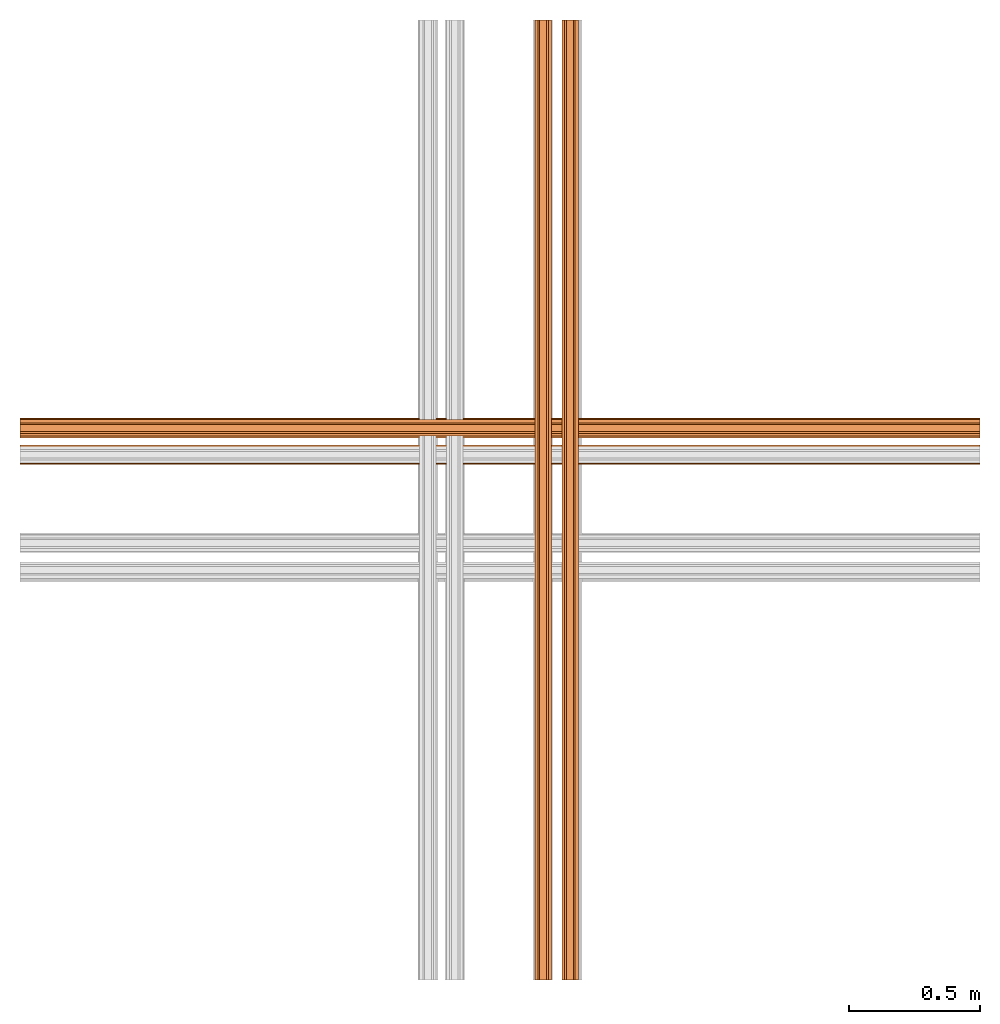
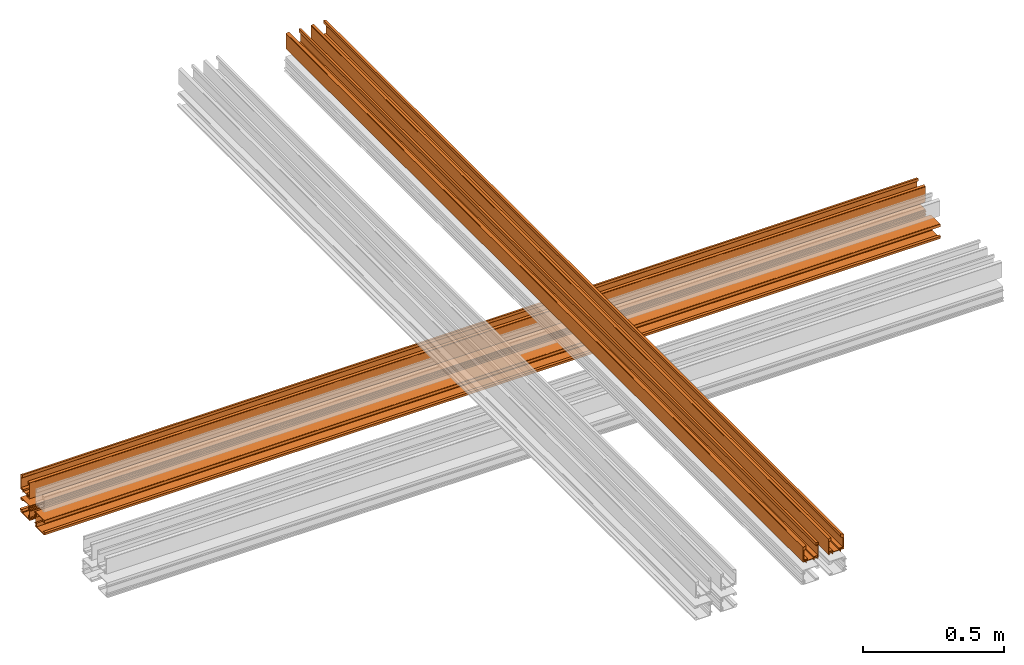
# One storey, part 2 of 4: 5 proxies.
"""IFC2X3 building model written with IfcOpenShell, lengths in feet."""

from ifc_helpers import new_model, entity, si_unit, converted_unit, derived_unit, direction, frame, origin, place, context, subcontext, project, spatial, polyline, outline, extrude, source, transform, mapped, material, type_object, type_shapes, element, save


model = new_model("IFC2X3")

# Units and contexts
model_context = context("Model", 3, precision=0.0001, world=origin(), true_north=direction((6.12303176911189e-17, 1.0)))
body_context = subcontext(model_context, "Body", "Model", "MODEL_VIEW")
ifc_project = project(units=[converted_unit("LENGTHUNIT", "FOOT", entity("IfcRatioMeasure", 0.3048), si_unit("LENGTHUNIT", "METRE"), dimensions=[1, 0, 0, 0, 0, 0, 0]), converted_unit("AREAUNIT", "SQUARE FOOT", entity("IfcRatioMeasure", 0.09290304), si_unit("AREAUNIT", "SQUARE_METRE"), dimensions=[2, 0, 0, 0, 0, 0, 0]), converted_unit("VOLUMEUNIT", "CUBIC FOOT", entity("IfcRatioMeasure", 0.028316846592), si_unit("VOLUMEUNIT", "CUBIC_METRE"), dimensions=[3, 0, 0, 0, 0, 0, 0]), converted_unit("PLANEANGLEUNIT", "DEGREE", entity("IfcRatioMeasure", 0.0174532925199433), si_unit("PLANEANGLEUNIT", "RADIAN"), dimensions=[0, 0, 0, 0, 0, 0, 0]), si_unit("MASSUNIT", "GRAM", prefix="KILO"), derived_unit("MASSDENSITYUNIT", [(si_unit("MASSUNIT", "GRAM", prefix="KILO"), 1), (si_unit("LENGTHUNIT", "METRE"), -3)]), si_unit("TIMEUNIT", "SECOND"), si_unit("FREQUENCYUNIT", "HERTZ"), si_unit("THERMODYNAMICTEMPERATUREUNIT", "DEGREE_CELSIUS"), derived_unit("THERMALTRANSMITTANCEUNIT", [(si_unit("MASSUNIT", "GRAM", prefix="KILO"), 1), (si_unit("THERMODYNAMICTEMPERATUREUNIT", "KELVIN"), -1), (si_unit("TIMEUNIT", "SECOND"), -3)]), derived_unit("VOLUMETRICFLOWRATEUNIT", [(si_unit("LENGTHUNIT", "METRE"), 3), (si_unit("TIMEUNIT", "SECOND"), -1)]), si_unit("ELECTRICCURRENTUNIT", "AMPERE"), si_unit("ELECTRICVOLTAGEUNIT", "VOLT"), si_unit("POWERUNIT", "WATT"), si_unit("FORCEUNIT", "NEWTON"), si_unit("ILLUMINANCEUNIT", "LUX"), si_unit("LUMINOUSFLUXUNIT", "LUMEN"), si_unit("LUMINOUSINTENSITYUNIT", "CANDELA"), derived_unit("USERDEFINED", [(si_unit("MASSUNIT", "GRAM", prefix="KILO"), -1), (si_unit("LENGTHUNIT", "METRE"), -2), (si_unit("TIMEUNIT", "SECOND"), 3), (si_unit("LUMINOUSFLUXUNIT", "LUMEN"), 1)]), derived_unit("LINEARVELOCITYUNIT", [(si_unit("LENGTHUNIT", "METRE"), 1), (si_unit("TIMEUNIT", "SECOND"), -1)]), si_unit("PRESSUREUNIT", "PASCAL"), derived_unit("USERDEFINED", [(si_unit("LENGTHUNIT", "METRE"), -2), (si_unit("MASSUNIT", "GRAM", prefix="KILO"), 1), (si_unit("TIMEUNIT", "SECOND"), -2)])], contexts=[model_context])

# Site, building, storey
site_placement = place(None, origin())
site = spatial("IfcSite", under=ifc_project, at=site_placement, CompositionType="ELEMENT")
building_placement = place(site_placement, origin())
building = spatial("IfcBuilding", under=site, at=building_placement, CompositionType="ELEMENT")
storey_placement = place(building_placement, origin())
storey = spatial("IfcBuildingStorey", under=building, at=storey_placement, Name="Level 1", CompositionType="ELEMENT", Elevation=0.0)

# Proxies
ifc_material = material(Name="THERMAL BROKEN ALUMINUM STOREFRONT FOR POLYCARBONATE")
building_element_proxy_type_1 = type_object("IfcBuildingElementProxyType", Name="Generic Models 2", PredefinedType="NOTDEFINED", material=ifc_material)
shared_shape_1 = source(origin(), body_context, "Body", "SweptSolid", [
    extrude(outline(polyline([(0.0679666623619384, 0.000632417738882034), (0.0710872151823903, 0.000632417738882035), (0.0725790120391962, 0.00314266314992642), (0.0702488184526767, 0.00635088523716412), (0.0700096732994308, 0.0109637083615167), (0.0775858665392128, 0.0113564851588285), (0.07705209294287, 0.0216523375102514), (-0.134304272308872, 0.0106948719853338), (-0.133377721915217, -0.00717717360587119), (-0.123081869563794, -0.00664340000952841), (-0.122412698736183, -0.000765203056200247), (-0.106181130798194, -0.00576720561552883), (-0.0921943125095251, -0.0050420792205001), (-0.0925870893068369, 0.002534114019282), (0.0533031958989615, 0.0100975851674486), (0.0553677918848111, -0.0297259946823094), (0.0598635549062831, -0.0294929183410442), (0.0628161856570255, 0.00318899968962119), (0.0662590259738256, 0.00336748877384732), (0.0679666623619384, 0.000632417738882034)])), frame((-15.047462540598, 0.320001633810749, 0.0977165289076384), z_axis=(1.0, 0.0, 0.0), x_axis=(0.0, -0.0517740246052117, -0.998658825813991)), (0.0, 0.0, 1.0), 12.0),
    extrude(outline(polyline([(-0.0104080468283571, -0.0212270141141864), (0.0284072982254619, -0.0212270141141864), (0.018596494374574, 0.0155635003266429), (-0.00515653981588799, 0.0270511459549446), (-0.00897742822638784, 0.0260322423788113), (-0.00514872339515063, 0.0116745992616715), (-0.00647401012520614, -0.00299045881680826), (-0.00136839731267838, -0.00250162354759878), (0.00181539143775607, -0.014440831361728), (-0.0112860383341234, -0.0179345459675626), (-0.0104080468283571, -0.0212270141141864)])), frame((-15.047462540598, 0.316819454437877, 0.217514651613355), z_axis=(1.0, 0.0, 0.0), x_axis=(0.0, -0.966234939601246, 0.257662650560335)), (0.0, 0.0, 1.0), 12.0),
    extrude(outline(polyline([(-0.0730229494703183, 0.10703462932325), (-0.0580447359626435, 0.10703462932325), (-0.0580447359626435, 0.113745897781071), (-0.0623242255363624, 0.118025006955696), (-0.0623242255363624, 0.112092207910207), (-0.067187281869896, 0.112092207910207), (-0.0704478474007049, 0.11773967307098), (-0.0704478474007049, 0.125224643652343), (-0.0675429204239739, 0.131454279657517), (-0.0623242255363623, 0.131454279657517), (-0.0623242255363623, 0.124783598829804), (-0.0580447359626435, 0.125514243391176), (-0.0580447359626435, 0.142048634925557), (-0.0813874063643328, 0.140085232742292), (-0.0813874063643332, -0.0647285203812247), (-0.0697160711634885, -0.0647285203812247), (-0.0697160711634885, -0.0853478792356713), (-0.0631023145498282, -0.0853478792356713), (-0.0631023145498281, -0.0647285203809973), (-0.0273102199340562, -0.0647285203809974), (-0.0273102199340562, -0.0853478792356714), (-0.0206964633203959, -0.0853478792356714), (-0.0206964633203958, -0.0647285203809974), (0.0812331974328893, -0.0647285203809976), (0.0812331974328893, -0.0853478792356715), (0.0878469540465496, -0.0853478792356716), (0.0878469540465497, -0.064728520381225), (0.116052680781773, -0.0647285203812251), (0.116052680781773, -0.060254508554083), (0.113329369234955, -0.058503808273967), (0.110217013181205, -0.0606435530609294), (0.0878469540467771, -0.0606435530609294), (0.0835674644730583, -0.0563640634872106), (0.0713125625121714, -0.0563640634872106), (0.0713125625121714, -0.038857060686171), (0.11546911402173, -0.0388570606861711), (0.11546911402173, -0.0337994820992142), (0.064698805898511, -0.0337994820992141), (0.064698805898511, -0.0563640634872106), (-0.0203074188135494, -0.0563640634872104), (-0.0203074188135494, -0.0337994820992139), (-0.0730229494703186, -0.0337994820992139), (-0.0730229494703183, 0.10703462932325)]), holes=[polyline([(-0.0710777269369962, -0.057725719260718), (-0.0710777269369961, -0.0388570606861708), (-0.0273102199340561, -0.0388570606861708), (-0.0273102199340562, -0.057725719260718), (-0.0710777269369962, -0.057725719260718)])]), frame((-15.047462540598, 0.210689707839806, 0.0853478792356716), z_axis=(1.0, 0.0, 0.0), x_axis=(0.0, 1.0, 0.0)), (0.0, 0.0, 1.0), 12.0),
    extrude(outline(polyline([(-0.0218274236802372, -0.0250762096884888), (0.0116463755794956, -0.0250762096884888), (0.0131456738465899, -0.018346801187307), (-0.00944342914962784, -0.0152716423802919), (-0.00556193395869953, 0.00214995231397128), (0.000832544625431264, 0.00182921635388849), (-0.000621696809064671, -0.00469796031725742), (0.00265859892029523, -0.00542880340721438), (0.00663400184610042, -0.000259219921661488), (0.00811823413249322, 0.00640256685218494), (0.00642611525779217, 0.0117890219260675), (0.00293818751194471, 0.0125661249989722), (0.00132974729935327, 0.00534684683544014), (-0.00324578604653776, 0.01254568596629), (-0.00165600184121945, 0.0196812290274095), (-0.0113732075341089, 0.0218462023164868), (-0.0218274236802372, -0.0250762096884888)])), frame((-15.047462540598, 0.147755316042005, 0.211232600832546), z_axis=(1.0, 0.0, 0.0), x_axis=(0.0, -0.976067916921979, -0.217465908950321)), (0.0, 0.0, 1.0), 12.0),
])
type_shapes(building_element_proxy_type_1, [shared_shape_1])
proxy_1_placement = place(storey_placement, frame((15.047462540598, 1.44024913148407, 0.30116151530084)))
element("IfcBuildingElementProxy", 1, at=proxy_1_placement, inside=storey, type_object=building_element_proxy_type_1, material=ifc_material, Name="Generic Models 4:Generic Models 2", ObjectType="Generic Models 4:Generic Models 2", context=body_context, shape_type="MappedRepresentation", body=[
    mapped(shared_shape_1, transform((0.0, 0.0, 0.0), scale=1.0)),
])
building_element_proxy_type_2 = type_object("IfcBuildingElementProxyType", Name="Generic Models 2", PredefinedType="NOTDEFINED", material=ifc_material)
shared_shape_2 = source(origin(), body_context, "Body", "SweptSolid", [
    extrude(outline(polyline([(-0.0178285177675846, -0.0155260272187081), (-0.0144209943882473, -0.0155260272187081), (-0.0144209943882478, -0.00196676824874534), (-0.00206457119881464, -0.00196676824874493), (-0.00122137518562342, -0.00702594432743685), (0.0126070394294666, -0.0019667682487444), (0.0274664100946021, -0.00196676824874392), (0.027466410094602, 0.00198764102989041), (0.0102463757664141, 0.0219787153649712), (-0.0278297824565667, 0.0219787153649699), (-0.0178285177675846, -0.0155260272187081)])), frame((-15.047462540598, -0.420840541578669, -0.488678668263246), z_axis=(1.0, 0.0, 0.0), x_axis=(0.0, 1.0, 0.0)), (0.0, 0.0, 1.0), 12.0),
    extrude(outline(polyline([(-0.0354587820648082, -0.0579874289764482), (-0.0371114306935165, -0.0606344277326359), (-0.0357721806658744, -0.0632292686235396), (-0.0318167433379171, -0.0629517678914729), (-0.0277772795930209, -0.0651918706200441), (-0.0314564692543414, -0.0718263669125336), (-0.0224403589082041, -0.076826291324035), (0.0801995988221872, 0.10825914370601), (0.0645489921835603, 0.116938257778832), (0.0595490677720589, 0.107922147432694), (0.064180835476401, 0.104241425091678), (0.0513416446814535, 0.0931221172418154), (0.0445492945375544, 0.0808738163942819), (0.0511837908300439, 0.0771946267329613), (-0.0196641946988635, -0.0505619557187232), (-0.0545378290564898, -0.0312226254478629), (-0.0567210844599414, -0.0351595792918129), (-0.0305624709345725, -0.0549725228627149), (-0.03223440063571, -0.0579874289764482), (-0.0354587820648082, -0.0579874289764482)])), frame((-15.047462540598, -0.301042418872953, -0.491860847636118), z_axis=(-1.0, 0.0, 0.0), x_axis=(0.0, -0.484973800275861, -0.874528680516533)), (0.0, 0.0, -1.0), 12.0),
    extrude(outline(polyline([(-0.10703462932325, -0.073022949470319), (-0.10703462932325, -0.0580447359626442), (-0.113745897781071, -0.0580447359626442), (-0.118025006955696, -0.062324225536363), (-0.112092207910207, -0.0623242255363631), (-0.112092207910207, -0.0671872818698967), (-0.11773967307098, -0.0704478474007056), (-0.125224643652343, -0.0704478474007056), (-0.131454279657517, -0.0675429204239747), (-0.131454279657517, -0.062324225536363), (-0.124783598829804, -0.062324225536363), (-0.125514243391176, -0.0580447359626443), (-0.142048634925557, -0.0580447359626443), (-0.140085232742292, -0.0813874063643334), (0.0647285203812248, -0.0813874063643335), (0.0647285203812249, -0.0697160711634889), (0.0853478792356714, -0.0697160711634888), (0.0853478792356714, -0.0631023145498285), (0.0647285203809975, -0.0631023145498285), (0.0647285203809975, -0.0273102199340566), (0.0853478792356714, -0.0273102199340566), (0.0853478792356714, -0.0206964633203962), (0.0647285203809975, -0.0206964633203962), (0.0647285203809975, 0.0812331974328889), (0.0853478792356714, 0.0812331974328889), (0.0853478792356714, 0.0878469540465494), (0.0647285203812249, 0.0878469540465494), (0.0647285203812249, 0.116052680781772), (0.0602545085540828, 0.116052680781772), (0.0585038082739668, 0.113329369234955), (0.0606435530609293, 0.110217013181204), (0.0606435530609293, 0.0878469540467767), (0.0563640634872104, 0.0835674644730579), (0.0563640634872104, 0.071312562512171), (0.0388570606861709, 0.071312562512171), (0.0388570606861709, 0.11546911402173), (0.033799482099214, 0.11546911402173), (0.033799482099214, 0.0646988058985107), (0.0563640634872105, 0.0646988058985107), (0.0563640634872105, -0.0203074188135498), (0.033799482099214, -0.0203074188135498), (0.033799482099214, -0.073022949470319), (-0.10703462932325, -0.073022949470319)]), holes=[polyline([(0.0577257192607181, -0.0710777269369965), (0.0388570606861709, -0.0710777269369965), (0.0388570606861709, -0.0273102199340565), (0.0577257192607181, -0.0273102199340565), (0.0577257192607181, -0.0710777269369965)])]), frame((-15.047462540598, -0.288673769200986, -0.382548921665175), z_axis=(-1.0, 0.0, 0.0), x_axis=(0.0, 1.0, 0.0)), (0.0, 0.0, -1.0), 12.0),
    extrude(outline(polyline([(-0.0292228042856086, -0.0158518272304065), (0.0188500922736236, -0.0158518272304065), (0.0188500922736236, -0.00589636662728316), (0.0115395937546052, -0.00589636662728316), (0.00550806035789692, 0.000135166769425155), (0.0129043470694794, 0.000135166769425099), (0.0129043470694794, 0.00370861456478611), (0.00801477925505995, 0.00653160785866191), (0.00118965299247947, 0.00653160785866191), (-0.00472072620232239, 0.003775552777526), (-0.00472072620232239, 0.000414827901224046), (0.00196648946985056, 0.000414827901224102), (0.000888968452729122, -0.0058963666272831), (-0.0169597840697409, -0.00589636662728321), (-0.0150489881052634, 0.0168208742845053), (-0.0219433941035703, 0.0168208742845053), (-0.0292228042856086, -0.0158518272304065)])), frame((-15.047462540598, -0.41455849079786, -0.319614529867374), z_axis=(1.0, 0.0, 0.0), x_axis=(0.0, 1.0, 0.0)), (0.0, 0.0, 1.0), 12.0),
])
type_shapes(building_element_proxy_type_2, [shared_shape_2])
proxy_2_placement = place(storey_placement, frame((15.047462540598, 1.66419438030405, 0.509494848634327)))
element("IfcBuildingElementProxy", 2, at=proxy_2_placement, inside=storey, type_object=building_element_proxy_type_2, material=ifc_material, Name="Generic Models 7:Generic Models 2", ObjectType="Generic Models 7:Generic Models 2", context=body_context, shape_type="MappedRepresentation", body=[
    mapped(shared_shape_2, transform((0.0, 0.0, 0.0), scale=1.0)),
])
building_element_proxy_type_3 = type_object("IfcBuildingElementProxyType", Name="Generic Models 2", PredefinedType="NOTDEFINED", material=ifc_material)
shared_shape_3 = source(origin(), body_context, "Body", "SweptSolid", [
    extrude(outline(polyline([(-0.0104080468283571, -0.0212270141141865), (0.0284072982254619, -0.0212270141141865), (0.0185964943745741, 0.0155635003266429), (-0.00515653981588791, 0.0270511459549447), (-0.00897742822638776, 0.0260322423788114), (-0.00514872339515044, 0.0116745992616716), (-0.0064740101252062, -0.00299045881680828), (-0.00136839731267846, -0.00250162354759874), (0.00181539143775597, -0.0144408313617281), (-0.0112860383341235, -0.0179345459675626), (-0.0104080468283571, -0.0212270141141865)])), frame((-15.0474625405981, 0.579193333610883, -0.488678668263244), z_axis=(1.0, 0.0, 0.0), x_axis=(0.0, 0.257662650560332, 0.966234939601246)), (0.0, 0.0, 1.0), 12.0),
    extrude(outline(polyline([(0.0679666623619383, 0.000632417738883341), (0.0710872151823902, 0.000632417738883342), (0.072579012039196, 0.00314266314992776), (0.0702488184526765, 0.00635088523716542), (0.0700096732994305, 0.0109637083615181), (0.0775858665392125, 0.0113564851588299), (0.0770520929428696, 0.0216523375102529), (-0.134304272308872, 0.0106948719853311), (-0.133377721915217, -0.00717717360587389), (-0.123081869563794, -0.00664340000953091), (-0.122412698736183, -0.000765203056202739), (-0.106181130798194, -0.00576720561553113), (-0.0921943125095252, -0.00504207922050203), (-0.092587089306837, 0.00253411401928001), (0.0533031958989612, 0.0100975851674497), (0.0553677918848116, -0.0297259946823082), (0.0598635549062836, -0.029492918341043), (0.0628161856570253, 0.00318899968962246), (0.0662590259738255, 0.00336748877384854), (0.0679666623619383, 0.000632417738883341)])), frame((-15.0474625405981, 0.459395210905167, -0.491860847636116), z_axis=(1.0, 0.0, 0.0), x_axis=(0.0, -0.99865882581399, 0.05177402460523)), (0.0, 0.0, 1.0), 12.0),
    extrude(outline(polyline([(-0.0730229494703184, 0.10703462932325), (-0.0580447359626436, 0.10703462932325), (-0.0580447359626436, 0.113745897781071), (-0.0623242255363625, 0.118025006955696), (-0.0623242255363624, 0.112092207910207), (-0.0671872818698961, 0.112092207910207), (-0.070447847400705, 0.11773967307098), (-0.070447847400705, 0.125224643652343), (-0.067542920423974, 0.131454279657517), (-0.0623242255363624, 0.131454279657517), (-0.0623242255363624, 0.124783598829804), (-0.0580447359626436, 0.125514243391176), (-0.0580447359626435, 0.142048634925557), (-0.0813874063643329, 0.140085232742292), (-0.0813874063643329, -0.0647285203812247), (-0.0697160711634882, -0.0647285203812247), (-0.0697160711634882, -0.0853478792356713), (-0.0631023145498278, -0.0853478792356712), (-0.0631023145498279, -0.0647285203809973), (-0.027310219934056, -0.0647285203809974), (-0.0273102199340559, -0.0853478792356713), (-0.0206964633203955, -0.0853478792356713), (-0.0206964633203956, -0.0647285203809974), (0.0812331974328895, -0.0647285203809974), (0.0812331974328896, -0.0853478792356713), (0.08784695404655, -0.0853478792356713), (0.0878469540465499, -0.0647285203812247), (0.116052680781773, -0.0647285203812247), (0.116052680781773, -0.0602545085540827), (0.113329369234955, -0.0585038082739666), (0.110217013181205, -0.0606435530609291), (0.0878469540467773, -0.0606435530609291), (0.0835674644730585, -0.0563640634872103), (0.0713125625121716, -0.0563640634872103), (0.0713125625121717, -0.0388570606861707), (0.115469114021731, -0.0388570606861707), (0.115469114021731, -0.0337994820992139), (0.0646988058985113, -0.0337994820992139), (0.0646988058985112, -0.0563640634872103), (-0.0203074188135492, -0.0563640634872103), (-0.0203074188135491, -0.0337994820992139), (-0.0730229494703184, -0.0337994820992138), (-0.0730229494703184, 0.10703462932325)]), holes=[polyline([(-0.0710777269369959, -0.057725719260718), (-0.0710777269369958, -0.0388570606861707), (-0.0273102199340559, -0.0388570606861707), (-0.027310219934056, -0.057725719260718), (-0.0710777269369959, -0.057725719260718)])]), frame((-15.0474625405981, 0.4470265612332, -0.382548921665172), z_axis=(1.0, 0.0, 0.0), x_axis=(0.0, 0.0, -1.0)), (0.0, 0.0, 1.0), 12.0),
    extrude(outline(polyline([(-0.0218274236802372, -0.025076209688489), (0.0116463755794956, -0.025076209688489), (0.0131456738465899, -0.0183468011873072), (-0.00944342914962783, -0.0152716423802922), (-0.00556193395869956, 0.00214995231397101), (0.000832544625431189, 0.00182921635388828), (-0.000621696809064723, -0.00469796031725753), (0.00265859892029526, -0.0054288034072145), (0.00663400184610042, -0.000259219921661603), (0.00811823413249314, 0.00640256685218482), (0.00642611525779212, 0.0117890219260673), (0.00293818751194467, 0.012566124998972), (0.00132974729935316, 0.00534684683544), (-0.00324578604653784, 0.0125456859662898), (-0.00165600184121952, 0.0196812290274093), (-0.011373207534109, 0.0218462023164866), (-0.0218274236802372, -0.025076209688489)])), frame((-15.0474625405981, 0.572911282830073, -0.319614529867372), z_axis=(1.0, 0.0, 0.0), x_axis=(0.0, -0.217465908950321, 0.976067916921979)), (0.0, 0.0, 1.0), 12.0),
])
type_shapes(building_element_proxy_type_3, [shared_shape_3])
proxy_3_placement = place(storey_placement, frame((15.047462540598, 1.18725339210734, 0.509494848634324)))
element("IfcBuildingElementProxy", 3, at=proxy_3_placement, inside=storey, type_object=building_element_proxy_type_3, material=ifc_material, Name="Generic Models 8:Generic Models 2", ObjectType="Generic Models 8:Generic Models 2", context=body_context, shape_type="MappedRepresentation", body=[
    mapped(shared_shape_3, transform((0.0, 0.0, 0.0), scale=1.0)),
])
building_element_proxy_type_4 = type_object("IfcBuildingElementProxyType", Name="Generic Models 2", PredefinedType="NOTDEFINED", material=ifc_material)
shared_shape_4 = source(origin(), body_context, "Body", "SweptSolid", [
    extrude(outline(polyline([(-0.0354587820648085, -0.057987428976448), (-0.0371114306935168, -0.0606344277326356), (-0.0357721806658748, -0.0632292686235394), (-0.0318167433379175, -0.0629517678914727), (-0.0277772795930213, -0.0651918706200439), (-0.0314564692543419, -0.0718263669125334), (-0.0224403589082045, -0.0768262913240349), (0.080199598822188, 0.108259143706009), (0.064548992183561, 0.116938257778831), (0.0595490677720596, 0.107922147432694), (0.0641808354764016, 0.104241425091678), (0.0513416446814541, 0.093122117241815), (0.0445492945375549, 0.0808738163942816), (0.0511837908300444, 0.0771946267329609), (-0.0196641946988638, -0.0505619557187231), (-0.0545378290564901, -0.0312226254478626), (-0.0567210844599416, -0.0351595792918124), (-0.0305624709345729, -0.0549725228627147), (-0.0322344006357104, -0.057987428976448), (-0.0354587820648085, -0.057987428976448)])), frame((0.0, -0.190699332335291, 0.0977165289076384), z_axis=(-1.0, 0.0, 0.0), x_axis=(0.0, -0.874528680516531, 0.484973800275866)), (0.0, 0.0, -1.0), 12.0),
    extrude(outline(polyline([(-0.0178285177675853, -0.0155260272187074), (-0.0144209943882479, -0.0155260272187074), (-0.0144209943882479, -0.00196676824874472), (-0.00206457119881483, -0.00196676824874479), (-0.00122137518562371, -0.00702594432743677), (0.0126070394294665, -0.00196676824874489), (0.027466410094602, -0.00196676824874498), (0.027466410094602, 0.00198764102988935), (0.0102463757664149, 0.0219787153649708), (-0.027829782456566, 0.021978715364971), (-0.0178285177675853, -0.0155260272187074)])), frame((0.0, -0.187517152962419, 0.217514651613355), z_axis=(1.0, 0.0, 0.0), x_axis=(0.0, 0.0, -1.0)), (0.0, 0.0, 1.0), 12.0),
    extrude(outline(polyline([(-0.10703462932325, -0.0730229494703186), (-0.10703462932325, -0.0580447359626438), (-0.113745897781071, -0.0580447359626438), (-0.118025006955696, -0.0623242255363626), (-0.112092207910207, -0.0623242255363626), (-0.112092207910207, -0.0671872818698963), (-0.11773967307098, -0.0704478474007052), (-0.125224643652343, -0.0704478474007052), (-0.131454279657517, -0.0675429204239743), (-0.131454279657517, -0.0623242255363626), (-0.124783598829804, -0.0623242255363626), (-0.125514243391176, -0.0580447359626438), (-0.142048634925557, -0.0580447359626438), (-0.140085232742292, -0.0813874063643331), (0.0647285203812249, -0.0813874063643331), (0.0647285203812249, -0.0697160711634884), (0.0853478792356714, -0.0697160711634884), (0.0853478792356714, -0.0631023145498281), (0.0647285203809975, -0.0631023145498281), (0.0647285203809975, -0.0273102199340561), (0.0853478792356715, -0.0273102199340561), (0.0853478792356715, -0.0206964633203958), (0.0647285203809975, -0.0206964633203958), (0.0647285203809975, 0.0812331974328894), (0.0853478792356714, 0.0812331974328894), (0.0853478792356714, 0.0878469540465497), (0.0647285203812249, 0.0878469540465497), (0.0647285203812249, 0.116052680781773), (0.0602545085540829, 0.116052680781773), (0.0585038082739668, 0.113329369234955), (0.0606435530609293, 0.110217013181205), (0.0606435530609293, 0.0878469540467771), (0.0563640634872104, 0.0835674644730583), (0.0563640634872105, 0.0713125625121714), (0.0388570606861708, 0.0713125625121714), (0.0388570606861709, 0.11546911402173), (0.033799482099214, 0.11546911402173), (0.033799482099214, 0.0646988058985111), (0.0563640634872104, 0.0646988058985111), (0.0563640634872105, -0.0203074188135494), (0.033799482099214, -0.0203074188135494), (0.033799482099214, -0.0730229494703186), (-0.10703462932325, -0.0730229494703186)]), holes=[polyline([(0.0577257192607181, -0.0710777269369961), (0.0388570606861709, -0.0710777269369961), (0.0388570606861709, -0.0273102199340561), (0.0577257192607181, -0.0273102199340561), (0.0577257192607181, -0.0710777269369961)])]), frame((0.0, -0.0813874063643477, 0.0853478792356716), z_axis=(-1.0, 0.0, 0.0), x_axis=(0.0, 0.0, -1.0)), (0.0, 0.0, -1.0), 12.0),
    extrude(outline(polyline([(-0.0292228042856085, -0.0158518272304065), (0.0188500922736237, -0.0158518272304065), (0.0188500922736237, -0.00589636662728312), (0.0115395937546053, -0.00589636662728311), (0.00550806035789697, 0.000135166769425167), (0.0129043470694795, 0.000135166769425165), (0.0129043470694795, 0.00370861456478618), (0.00801477925506001, 0.00653160785866192), (0.00118965299247954, 0.00653160785866192), (-0.00472072620232233, 0.00377555277752608), (-0.00472072620232233, 0.000414827901224136), (0.00196648946985067, 0.000414827901224136), (0.00088896845272922, -0.00589636662728308), (-0.0169597840697408, -0.00589636662728307), (-0.0150489881052633, 0.0168208742845053), (-0.0219433941035701, 0.0168208742845053), (-0.0292228042856085, -0.0158518272304065)])), frame((0.0, -0.0184530145665469, 0.211232600832546), z_axis=(1.0, 0.0, 0.0), x_axis=(0.0, 0.0, -1.0)), (0.0, 0.0, 1.0), 12.0),
])
type_shapes(building_element_proxy_type_4, [shared_shape_4])
proxy_4_placement = place(storey_placement, frame((6.77203780910475, -5.22796219089525, 1.25949484863417), z_axis=(0.0, 0.0, 1.0), x_axis=(0.0, 1.0, 0.0)))
element("IfcBuildingElementProxy", 4, at=proxy_4_placement, inside=storey, type_object=building_element_proxy_type_4, material=ifc_material, Name="Generic Models 9:Generic Models 2", ObjectType="Generic Models 9:Generic Models 2", context=body_context, shape_type="MappedRepresentation", body=[
    mapped(shared_shape_4, transform((0.0, 0.0, 0.0), scale=1.0)),
])
building_element_proxy_type_5 = type_object("IfcBuildingElementProxyType", Name="Generic Models 2", PredefinedType="NOTDEFINED", material=ifc_material)
shared_shape_5 = source(origin(), body_context, "Body", "SweptSolid", [
    extrude(outline(polyline([(0.0679666623619384, 0.000632417738882162), (0.0710872151823903, 0.000632417738882162), (0.0725790120391962, 0.00314266314992655), (0.0702488184526767, 0.00635088523716425), (0.0700096732994308, 0.0109637083615168), (0.0775858665392128, 0.0113564851588286), (0.07705209294287, 0.0216523375102515), (-0.134304272308872, 0.0106948719853338), (-0.133377721915217, -0.00717717360587128), (-0.123081869563794, -0.00664340000952848), (-0.122412698736183, -0.000765203056200318), (-0.106181130798194, -0.00576720561552888), (-0.0921943125095252, -0.00504207922050014), (-0.0925870893068369, 0.00253411401928196), (0.0533031958989614, 0.0100975851674487), (0.0553677918848112, -0.0297259946823093), (0.0598635549062831, -0.0294929183410441), (0.0628161856570255, 0.00318899968962131), (0.0662590259738257, 0.00336748877384745), (0.0679666623619384, 0.000632417738882162)])), frame((0.0, 0.320001633810788, 0.0977165289076384), z_axis=(1.0, 0.0, 0.0), x_axis=(0.0, -0.0517740246052127, -0.998658825813991)), (0.0, 0.0, 1.0), 12.0),
    extrude(outline(polyline([(-0.0104080468283571, -0.0212270141141865), (0.0284072982254618, -0.0212270141141865), (0.0185964943745739, 0.0155635003266429), (-0.00515653981588804, 0.0270511459549446), (-0.00897742822638789, 0.0260322423788113), (-0.00514872339515063, 0.0116745992616715), (-0.0064740101252062, -0.00299045881680825), (-0.00136839731267844, -0.0025016235475988), (0.00181539143775603, -0.0144408313617281), (-0.0112860383341235, -0.0179345459675626), (-0.0104080468283571, -0.0212270141141865)])), frame((0.0, 0.316819454437916, 0.217514651613355), z_axis=(1.0, 0.0, 0.0), x_axis=(0.0, -0.966234939601246, 0.257662650560335)), (0.0, 0.0, 1.0), 12.0),
    extrude(outline(polyline([(-0.0730229494703184, 0.10703462932325), (-0.0580447359626436, 0.10703462932325), (-0.0580447359626435, 0.113745897781071), (-0.0623242255363624, 0.118025006955696), (-0.0623242255363624, 0.112092207910207), (-0.067187281869896, 0.112092207910207), (-0.0704478474007049, 0.11773967307098), (-0.0704478474007049, 0.125224643652343), (-0.067542920423974, 0.131454279657517), (-0.0623242255363623, 0.131454279657517), (-0.0623242255363623, 0.124783598829804), (-0.0580447359626436, 0.125514243391176), (-0.0580447359626435, 0.142048634925557), (-0.0813874063643328, 0.140085232742292), (-0.0813874063643332, -0.0647285203812247), (-0.0697160711634885, -0.0647285203812247), (-0.0697160711634886, -0.0853478792356713), (-0.0631023145498282, -0.0853478792356713), (-0.0631023145498282, -0.0647285203809974), (-0.0273102199340562, -0.0647285203809974), (-0.0273102199340562, -0.0853478792356714), (-0.0206964633203959, -0.0853478792356714), (-0.0206964633203959, -0.0647285203809975), (0.0812331974328893, -0.0647285203809976), (0.0812331974328893, -0.0853478792356716), (0.0878469540465496, -0.0853478792356716), (0.0878469540465496, -0.064728520381225), (0.116052680781773, -0.0647285203812251), (0.116052680781773, -0.060254508554083), (0.113329369234955, -0.058503808273967), (0.110217013181205, -0.0606435530609294), (0.0878469540467771, -0.0606435530609294), (0.0835674644730583, -0.0563640634872106), (0.0713125625121714, -0.0563640634872106), (0.0713125625121713, -0.038857060686171), (0.11546911402173, -0.0388570606861711), (0.11546911402173, -0.0337994820992142), (0.064698805898511, -0.0337994820992141), (0.064698805898511, -0.0563640634872105), (-0.0203074188135494, -0.0563640634872104), (-0.0203074188135494, -0.033799482099214), (-0.0730229494703186, -0.0337994820992139), (-0.0730229494703184, 0.10703462932325)]), holes=[polyline([(-0.0710777269369962, -0.057725719260718), (-0.0710777269369962, -0.0388570606861707), (-0.0273102199340562, -0.0388570606861708), (-0.0273102199340562, -0.0577257192607181), (-0.0710777269369962, -0.057725719260718)])]), frame((0.0, 0.210689707839845, 0.0853478792356716), z_axis=(1.0, 0.0, 0.0), x_axis=(0.0, 1.0, 0.0)), (0.0, 0.0, 1.0), 12.0),
    extrude(outline(polyline([(-0.0218274236802372, -0.0250762096884888), (0.0116463755794956, -0.0250762096884888), (0.0131456738465899, -0.0183468011873071), (-0.00944342914962784, -0.0152716423802919), (-0.00556193395869954, 0.00214995231397123), (0.000832544625431264, 0.00182921635388849), (-0.000621696809064671, -0.00469796031725742), (0.00265859892029523, -0.00542880340721438), (0.00663400184610042, -0.000259219921661488), (0.00811823413249319, 0.00640256685218492), (0.00642611525779217, 0.0117890219260675), (0.00293818751194471, 0.0125661249989722), (0.00132974729935321, 0.0053468468354401), (-0.00324578604653776, 0.01254568596629), (-0.00165600184121947, 0.0196812290274094), (-0.0113732075341089, 0.0218462023164868), (-0.0218274236802372, -0.0250762096884888)])), frame((0.0, 0.147755316042044, 0.211232600832546), z_axis=(1.0, 0.0, 0.0), x_axis=(0.0, -0.976067916921979, -0.217465908950321)), (0.0, 0.0, 1.0), 12.0),
])
type_shapes(building_element_proxy_type_5, [shared_shape_5])
proxy_5_placement = place(storey_placement, frame((6.77203780910475, -5.22796219089525, 1.25949484863417), z_axis=(0.0, 0.0, 1.0), x_axis=(0.0, 1.0, 0.0)))
element("IfcBuildingElementProxy", 5, at=proxy_5_placement, inside=storey, type_object=building_element_proxy_type_5, material=ifc_material, Name="Generic Models 10:Generic Models 2", ObjectType="Generic Models 10:Generic Models 2", context=body_context, shape_type="MappedRepresentation", body=[
    mapped(shared_shape_5, transform((0.0, 0.0, 0.0), scale=1.0)),
])

save(model, "model.ifc")
